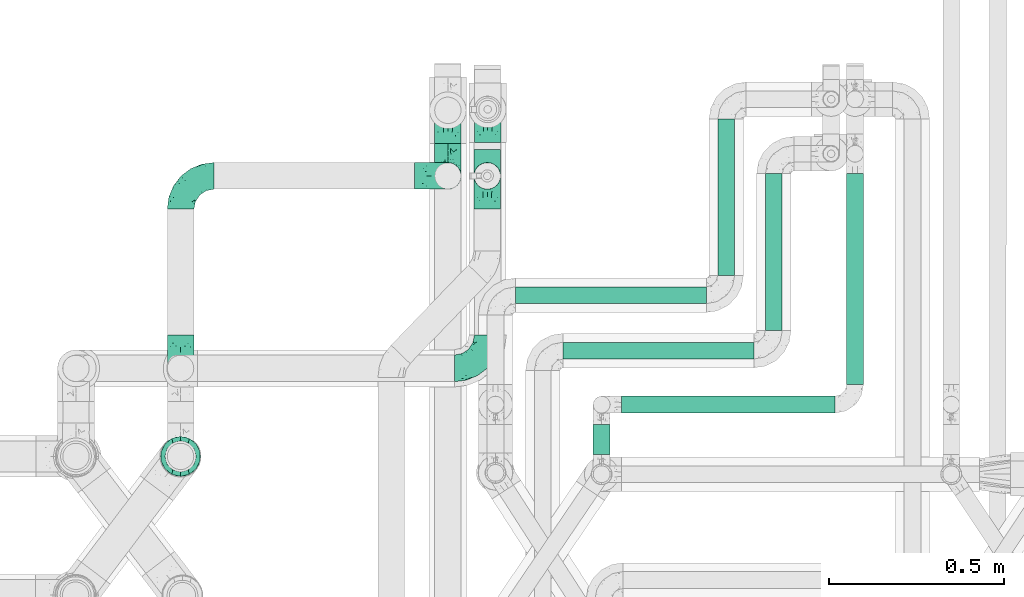
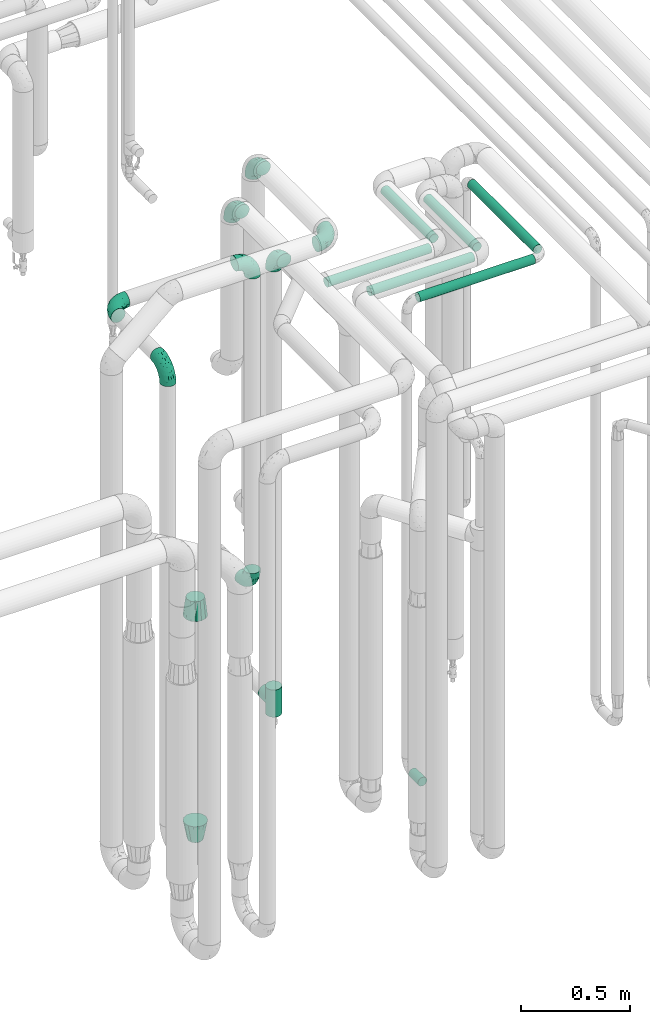
# One storey, part 671 of 824: 11 flow fittings, 7 flow segments.
"""IFC2X3 building model written with IfcOpenShell, lengths in millimetres."""

from ifc_helpers import new_model, entity, si_unit, converted_unit, derived_unit, direction, frame, origin, origin_2d_with_axis, place, context, subcontext, project, spatial, circle, extrude, faceted_brep, source, transform, mapped, material, type_object, type_shapes, element, save


model = new_model("IFC2X3")

# Units and contexts
model_context = context("Model", 3, precision=0.01, world=origin(), true_north=direction((6.12303176911189e-17, 1.0)))
body_context = subcontext(model_context, "Body", "Model", "MODEL_VIEW")
ifc_project = project(units=[si_unit("LENGTHUNIT", "METRE", prefix="MILLI"), si_unit("AREAUNIT", "SQUARE_METRE"), si_unit("VOLUMEUNIT", "CUBIC_METRE"), converted_unit("PLANEANGLEUNIT", "DEGREE", entity("IfcRatioMeasure", 0.0174532925199433), si_unit("PLANEANGLEUNIT", "RADIAN"), dimensions=[0, 0, 0, 0, 0, 0, 0]), si_unit("MASSUNIT", "GRAM", prefix="KILO"), derived_unit("MASSDENSITYUNIT", [(si_unit("MASSUNIT", "GRAM", prefix="KILO"), 1), (si_unit("LENGTHUNIT", "METRE"), -3)]), derived_unit("MOMENTOFINERTIAUNIT", [(si_unit("LENGTHUNIT", "METRE"), 4)]), si_unit("TIMEUNIT", "SECOND"), si_unit("FREQUENCYUNIT", "HERTZ"), si_unit("THERMODYNAMICTEMPERATUREUNIT", "DEGREE_CELSIUS"), derived_unit("THERMALTRANSMITTANCEUNIT", [(si_unit("MASSUNIT", "GRAM", prefix="KILO"), 1), (si_unit("THERMODYNAMICTEMPERATUREUNIT", "KELVIN"), -1), (si_unit("TIMEUNIT", "SECOND"), -3)]), derived_unit("VOLUMETRICFLOWRATEUNIT", [(si_unit("LENGTHUNIT", "METRE"), 3), (si_unit("TIMEUNIT", "SECOND"), -1)]), derived_unit("MASSFLOWRATEUNIT", [(si_unit("MASSUNIT", "GRAM", prefix="KILO"), 1), (si_unit("TIMEUNIT", "SECOND"), -1)]), derived_unit("ROTATIONALFREQUENCYUNIT", [(si_unit("TIMEUNIT", "SECOND"), -1)]), si_unit("ELECTRICCURRENTUNIT", "AMPERE"), si_unit("ELECTRICVOLTAGEUNIT", "VOLT"), si_unit("POWERUNIT", "WATT"), si_unit("FORCEUNIT", "NEWTON", prefix="KILO"), si_unit("ILLUMINANCEUNIT", "LUX"), si_unit("LUMINOUSFLUXUNIT", "LUMEN"), si_unit("LUMINOUSINTENSITYUNIT", "CANDELA"), derived_unit("USERDEFINED", [(si_unit("MASSUNIT", "GRAM", prefix="KILO"), -1), (si_unit("LENGTHUNIT", "METRE"), -2), (si_unit("TIMEUNIT", "SECOND"), 3), (si_unit("LUMINOUSFLUXUNIT", "LUMEN"), 1)]), derived_unit("LINEARVELOCITYUNIT", [(si_unit("LENGTHUNIT", "METRE"), 1), (si_unit("TIMEUNIT", "SECOND"), -1)]), si_unit("PRESSUREUNIT", "PASCAL"), derived_unit("USERDEFINED", [(si_unit("LENGTHUNIT", "METRE"), -2), (si_unit("MASSUNIT", "GRAM", prefix="KILO"), 1), (si_unit("TIMEUNIT", "SECOND"), -2)]), derived_unit("LINEARFORCEUNIT", [(si_unit("MASSUNIT", "GRAM", prefix="KILO"), 1), (si_unit("LENGTHUNIT", "METRE"), 1), (si_unit("TIMEUNIT", "SECOND"), -2), (si_unit("LENGTHUNIT", "METRE"), -1)]), derived_unit("PLANARFORCEUNIT", [(si_unit("MASSUNIT", "GRAM", prefix="KILO"), 1), (si_unit("LENGTHUNIT", "METRE"), 1), (si_unit("TIMEUNIT", "SECOND"), -2), (si_unit("LENGTHUNIT", "METRE"), -2)])], contexts=[model_context])

# Site, building, storey
site_placement = place(None, origin())
site = spatial("IfcSite", under=ifc_project, at=site_placement, CompositionType="ELEMENT")
building_placement = place(site_placement, origin())
building = spatial("IfcBuilding", under=site, at=building_placement, CompositionType="ELEMENT")
storey_placement = place(building_placement, frame((0.0, 0.0, 28200.0)))
storey = spatial("IfcBuildingStorey", under=building, at=storey_placement, CompositionType="ELEMENT", Elevation=28200.0)

# Flow segments
pipe_segment_type = type_object("IfcPipeSegmentType", PredefinedType="NOTDEFINED")
flow_segment_1_placement = place(storey_placement, frame((47694.42, 14491.53, 2974.4)))
element("IfcFlowSegment", 1, at=flow_segment_1_placement, inside=storey, type_object=pipe_segment_type, context=body_context, shape_type="SweptSolid", body=[
    extrude(circle(Radius=24.0, at=origin_2d_with_axis()), frame((25.6, 0.0, 25.6), z_axis=(0.0, 1.0, 0.0), x_axis=(1.0, 0.0, 0.0)), (0.0, 0.0, 1.0), 602.710728474916),
])
flow_segment_2_placement = place(storey_placement, frame((47462.4, 14645.75, 2974.4)))
element("IfcFlowSegment", 2, at=flow_segment_2_placement, inside=storey, type_object=pipe_segment_type, context=body_context, shape_type="SweptSolid", body=[
    extrude(circle(Radius=24.0, at=origin_2d_with_axis()), frame((25.6, 0.0, 25.6), z_axis=(0.0, 1.0, 0.0), x_axis=(-1.0, 0.0, 0.0)), (0.0, 0.0, 1.0), 448.489185095073),
])
flow_segment_3_placement = place(storey_placement, frame((47326.4, 14804.03, 2974.4)))
element("IfcFlowSegment", 3, at=flow_segment_3_placement, inside=storey, type_object=pipe_segment_type, context=body_context, shape_type="SweptSolid", body=[
    extrude(circle(Radius=24.0, at=origin_2d_with_axis()), frame((25.6, 0.0, 25.6), z_axis=(0.0, 1.0, 0.0), x_axis=(-1.0, 0.0, 0.0)), (0.0, 0.0, 1.0), 446.000000000016),
])
flow_segment_4_placement = place(storey_placement, frame((46970.44, 14292.68, 374.4)))
element("IfcFlowSegment", 4, at=flow_segment_4_placement, inside=storey, type_object=pipe_segment_type, context=body_context, shape_type="SweptSolid", body=[
    extrude(circle(Radius=24.0, at=origin_2d_with_axis()), frame((25.6, 0.0, 25.6), z_axis=(0.0, 1.0, 0.0), x_axis=(-1.0, 0.0, 0.0)), (0.0, 0.0, 1.0), 84.8501728348417),
])
flow_segment_5_placement = place(storey_placement, frame((47053.03, 14408.93, 2974.4)))
element("IfcFlowSegment", 5, at=flow_segment_5_placement, inside=storey, type_object=pipe_segment_type, context=body_context, shape_type="SweptSolid", body=[
    extrude(circle(Radius=24.0, at=origin_2d_with_axis()), frame((0.0, 25.6, 25.6), z_axis=(1.0, 0.0, 0.0), x_axis=(0.0, 1.0, 0.0)), (0.0, 0.0, 1.0), 609.986534506505),
])
flow_segment_6_placement = place(storey_placement, frame((46885.0, 14563.15, 2974.4)))
element("IfcFlowSegment", 6, at=flow_segment_6_placement, inside=storey, type_object=pipe_segment_type, context=body_context, shape_type="SweptSolid", body=[
    extrude(circle(Radius=24.0, at=origin_2d_with_axis()), frame((0.0, 25.6, 25.6), z_axis=(1.0, 0.0, 0.0), x_axis=(0.0, 1.0, 0.0)), (0.0, 0.0, 1.0), 546.000000000006),
])
flow_segment_7_placement = place(storey_placement, frame((46749.79, 14721.43, 2974.4)))
element("IfcFlowSegment", 7, at=flow_segment_7_placement, inside=storey, type_object=pipe_segment_type, context=body_context, shape_type="SweptSolid", body=[
    extrude(circle(Radius=24.0, at=origin_2d_with_axis()), frame((0.0, 25.6, 25.6), z_axis=(1.0, 0.0, 0.0), x_axis=(0.0, 1.0, 0.0)), (0.0, 0.0, 1.0), 545.208916433662),
])

# Flow fittings
ifc_material = material()
pipe_fitting_type_1 = type_object("IfcPipeFittingType", PredefinedType="NOTDEFINED", material=ifc_material)
shared_shape_1 = source(origin(), body_context, "Body", "Brep", [
    faceted_brep([(-95.0, 19.02, -32.95), (-95.0, 9.85, -36.75), (-95.0, 0.0, -38.05), (-95.0, -9.85, -36.75), (-95.0, -19.03, -32.95), (-95.0, -26.91, -26.91), (-95.0, -32.95, -19.03), (-95.0, -36.75, -9.85), (-95.0, -38.05, 0.0), (-95.0, -36.75, 9.85), (-95.0, -32.95, 19.02), (-95.0, -26.91, 26.91), (-95.0, -19.03, 32.95), (-95.0, -9.85, 36.75), (-95.0, 0.0, 38.05), (-95.0, 9.85, 36.75), (-95.0, 19.02, 32.95), (-95.0, 26.91, 26.91), (-95.0, 32.95, 19.02), (-95.0, 36.75, 9.85), (-95.0, 38.05, 0.0), (-95.0, 36.75, -9.85), (-95.0, 32.95, -19.03), (-95.0, 26.91, -26.91), (0.0, 95.0, -38.05), (-9.85, 95.0, -36.75), (-19.02, 95.0, -32.95), (-26.91, 95.0, -26.91), (-32.95, 95.0, -19.03), (-36.75, 95.0, -9.85), (-38.05, 95.0, 0.0), (-36.75, 95.0, 9.85), (-32.95, 95.0, 19.02), (-26.91, 95.0, 26.91), (-19.02, 95.0, 32.95), (-9.85, 95.0, 36.75), (0.0, 95.0, 38.05), (9.85, 95.0, 36.75), (19.03, 95.0, 32.95), (26.91, 95.0, 26.91), (32.95, 95.0, 19.02), (36.75, 95.0, 9.85), (38.05, 95.0, 0.0), (36.75, 95.0, -9.85), (32.95, 95.0, -19.03), (26.91, 95.0, -26.91), (19.03, 95.0, -32.95), (9.85, 95.0, -36.75), (-7.99, -4.96, 6.3), (-0.92, 0.92, 0.0), (4.62, 8.1, 8.01), (-76.19, -35.57, 0.0), (-64.32, -32.32, 12.43), (20.51, 62.45, 28.68), (-60.56, -33.52, 0.0), (-70.4, -13.47, 34.42), (-39.61, -5.88, 32.32), (-49.6, 2.07, 37.1), (-70.34, -28.81, 21.71), (14.64, 40.81, 26.5), (5.88, 39.61, 32.32), (3.59, 20.77, 25.31), (-40.45, 68.06, 16.75), (-62.45, -20.51, 28.68), (-44.52, -26.87, 0.0), (-28.47, -20.22, 0.0), (-26.43, -17.83, 8.75), (-76.1, 39.63, 10.76), (-72.74, 37.58, 18.19), (-60.35, 46.18, 14.61), (-13.4, 13.4, 32.12), (-20.77, -3.59, 25.31), (-14.66, 81.47, 35.56), (-6.22, 71.26, 37.92), (-57.5, 42.48, 22.79), (-15.0, 34.74, 37.7), (-27.1, 12.08, 36.05), (-9.2, 28.81, 35.63), (-79.98, 23.7, 30.95), (-73.68, -4.3, 37.48), (-30.74, 21.67, 37.97), (-62.36, 47.59, 6.79), (-72.71, 32.83, 24.69), (-67.42, 7.02, 37.95), (-32.13, 75.27, 24.51), (-43.46, 51.47, 26.26), (-24.98, 73.15, 31.29), (20.59, 41.28, 19.85), (7.79, 16.09, 15.86), (-73.21, 42.39, 0.0), (-54.73, 54.73, 0.0), (-73.44, 15.79, 35.79), (-5.94, 4.32, 20.43), (28.81, 70.34, 21.71), (32.32, 64.32, 12.43), (-53.59, 26.2, 35.09), (-52.02, 19.31, 37.21), (21.38, 33.53, 10.34), (26.87, 44.52, 0.0), (-48.28, 12.14, 38.05), (4.3, 73.68, 37.48), (-44.08, -25.52, 12.79), (-41.28, -20.59, 19.85), (35.57, 76.19, 0.0), (-47.26, 54.3, 20.18), (-47.4, 61.99, 8.58), (-42.39, 73.21, 0.0), (-39.67, 78.86, 7.21), (-45.69, 36.84, 33.11), (-32.83, 50.13, 33.35), (13.47, 70.4, 34.42), (-18.25, 63.73, 36.07), (-40.63, -13.75, 27.22), (-16.63, 46.37, 37.95), (-53.47, 38.79, 28.59), (-26.07, 48.54, 36.15), (-34.51, 34.51, 36.86), (-2.07, 49.6, 37.1), (-22.79, -10.49, 19.23), (-61.73, 28.67, 31.87), (9.65, 14.7, 0.0), (20.22, 28.47, 0.0), (33.52, 60.56, 0.0), (-11.42, -5.44, 13.25), (-14.7, -9.65, 0.0), (-81.47, 14.66, -35.56), (-62.45, -20.51, -28.68), (-71.26, 6.22, -37.92), (-75.27, 32.13, -24.51), (-73.15, 24.98, -31.29), (13.47, 70.4, -34.42), (5.88, 39.61, -32.32), (-2.07, 49.6, -37.1), (-78.86, 39.67, -7.21), (-70.4, -13.47, -34.42), (-39.61, -5.88, -32.32), (-61.99, 47.4, -8.58), (32.32, 64.32, -12.43), (28.81, 70.34, -21.71), (-63.73, 18.25, -36.07), (-50.13, 32.83, -33.35), (4.3, 73.68, -37.48), (-7.02, 67.42, -37.95), (-39.63, 76.1, -10.76), (-46.18, 60.35, -14.61), (-47.59, 62.36, -6.79), (-64.32, -32.32, -12.43), (-26.2, 53.59, -35.09), (-15.79, 73.44, -35.79), (-19.31, 52.02, -37.21), (-37.58, 72.74, -18.19), (-70.34, -28.81, -21.71), (-42.48, 57.5, -22.79), (-38.79, 53.47, -28.59), (-51.47, 43.46, -26.26), (-32.83, 72.71, -24.69), (-46.37, 16.63, -37.95), (-73.68, -4.3, -37.48), (-41.28, -20.59, -19.85), (-44.08, -25.52, -12.79), (13.75, 40.63, -27.22), (20.51, 62.45, -28.68), (-68.06, 40.45, -16.75), (-54.3, 47.26, -20.18), (-12.14, 48.28, -38.05), (-21.67, 30.74, -37.97), (-36.84, 45.69, -33.11), (-11.42, -5.44, -13.25), (7.79, 16.09, -15.86), (4.62, 8.1, -8.01), (-23.7, 79.98, -30.95), (-26.43, -17.83, -8.75), (-7.99, -4.96, -6.3), (-40.81, -14.64, -26.5), (-20.77, -3.59, -25.31), (-34.74, 15.0, -37.7), (-12.08, 27.1, -36.05), (-28.81, 9.2, -35.63), (-22.79, -10.49, -19.23), (21.38, 33.53, -10.34), (20.59, 41.28, -19.85), (-48.54, 26.07, -36.15), (-49.6, 2.07, -37.1), (-13.4, 13.4, -32.12), (3.59, 20.77, -25.31), (-28.67, 61.73, -31.87), (-34.51, 34.51, -36.86), (-5.94, 4.32, -20.43)], [[[0, 1, 2, 3, 4, 5, 6, 7, 8, 9, 10, 11, 12, 13, 14, 15, 16, 17, 18, 19, 20, 21, 22, 23]], [[24, 25, 26, 27, 28, 29, 30, 31, 32, 33, 34, 35, 36, 37, 38, 39, 40, 41, 42, 43, 44, 45, 46, 47]], [[48, 49, 50]], [[51, 52, 9]], [[53, 39, 38]], [[9, 52, 10]], [[54, 52, 51]], [[55, 56, 57]], [[11, 10, 58]], [[59, 60, 61]], [[32, 31, 62]], [[63, 12, 11]], [[63, 55, 12]], [[64, 65, 66]], [[67, 68, 69]], [[70, 56, 71]], [[35, 72, 73]], [[69, 68, 74]], [[75, 76, 77]], [[16, 78, 17]], [[13, 79, 14]], [[76, 75, 80]], [[67, 69, 81]], [[18, 17, 82]], [[14, 79, 83]], [[20, 19, 67]], [[84, 85, 86]], [[87, 61, 88]], [[89, 81, 90]], [[18, 82, 68]], [[15, 91, 16]], [[14, 83, 15]], [[71, 92, 61]], [[17, 78, 82]], [[93, 87, 94]], [[95, 91, 96]], [[97, 98, 94]], [[86, 72, 34]], [[96, 99, 80]], [[37, 36, 100]], [[40, 39, 93]], [[40, 94, 41]], [[64, 66, 101]], [[93, 94, 40]], [[58, 102, 63]], [[94, 103, 41]], [[94, 87, 97]], [[104, 69, 74]], [[34, 33, 86]], [[105, 69, 104]], [[52, 58, 10]], [[106, 107, 30]], [[108, 109, 85]], [[105, 106, 90]], [[53, 110, 60]], [[86, 111, 72]], [[86, 109, 111]], [[33, 84, 86]], [[12, 55, 13]], [[112, 56, 63]], [[110, 38, 37]], [[34, 72, 35]], [[36, 35, 73]], [[111, 113, 73]], [[105, 107, 106]], [[110, 53, 38]], [[74, 114, 85]], [[91, 15, 83]], [[105, 90, 81]], [[107, 62, 31]], [[33, 32, 84]], [[115, 109, 116]], [[111, 115, 113]], [[100, 73, 117]], [[56, 55, 63]], [[79, 55, 57]], [[102, 118, 112]], [[56, 70, 76]], [[100, 110, 37]], [[117, 77, 60]], [[117, 60, 110]], [[60, 70, 61]], [[58, 52, 101]], [[63, 11, 58]], [[39, 53, 93]], [[87, 93, 53]], [[96, 91, 83]], [[78, 91, 119]], [[32, 62, 84]], [[84, 62, 104]], [[86, 85, 109]], [[85, 114, 108]], [[80, 113, 116]], [[117, 73, 113]], [[80, 116, 96]], [[80, 57, 76]], [[71, 112, 118]], [[61, 87, 59]], [[62, 107, 105]], [[97, 120, 121]], [[70, 71, 61]], [[71, 118, 92]], [[73, 100, 36]], [[110, 100, 117]], [[55, 79, 13]], [[83, 79, 57]], [[96, 83, 99]], [[116, 108, 95]], [[50, 97, 88]], [[97, 87, 88]], [[50, 49, 120]], [[122, 94, 98]], [[89, 20, 67]], [[105, 81, 69]], [[89, 67, 81]], [[68, 19, 18]], [[68, 67, 19]], [[74, 68, 82]], [[114, 82, 119]], [[74, 85, 104]], [[82, 114, 74]], [[114, 119, 108]], [[95, 108, 119]], [[116, 109, 108]], [[123, 48, 50]], [[97, 50, 120]], [[123, 50, 88]], [[91, 95, 119]], [[116, 95, 96]], [[84, 104, 85]], [[104, 62, 105]], [[83, 57, 99]], [[57, 80, 99]], [[66, 48, 123]], [[66, 124, 48]], [[118, 66, 123]], [[124, 66, 65]], [[66, 118, 101]], [[54, 64, 52]], [[124, 49, 48]], [[30, 107, 31]], [[91, 78, 16]], [[82, 78, 119]], [[56, 76, 57]], [[77, 76, 70]], [[60, 77, 70]], [[77, 117, 75]], [[117, 113, 75]], [[113, 80, 75]], [[9, 8, 51]], [[103, 94, 122]], [[103, 42, 41]], [[73, 72, 111]], [[113, 115, 116]], [[111, 109, 115]], [[102, 112, 63]], [[71, 56, 112]], [[118, 102, 101]], [[92, 123, 88]], [[123, 92, 118]], [[61, 92, 88]], [[87, 53, 59]], [[60, 59, 53]], [[97, 121, 98]], [[58, 101, 102]], [[64, 101, 52]], [[125, 1, 0]], [[126, 5, 4]], [[2, 1, 127]], [[1, 125, 127]], [[128, 129, 23]], [[130, 131, 132]], [[89, 133, 20]], [[126, 134, 135]], [[136, 89, 90]], [[137, 138, 44]], [[139, 129, 140]], [[24, 141, 142]], [[143, 144, 145]], [[125, 129, 139]], [[6, 146, 7]], [[147, 148, 149]], [[146, 51, 7]], [[143, 150, 144]], [[146, 6, 151]], [[152, 153, 154]], [[126, 4, 134]], [[0, 23, 129]], [[28, 155, 150]], [[43, 42, 103]], [[54, 146, 64]], [[139, 156, 127]], [[157, 3, 2]], [[151, 158, 159]], [[160, 131, 161]], [[22, 21, 162]], [[136, 144, 163]], [[149, 164, 165]], [[24, 142, 25]], [[166, 140, 154]], [[154, 129, 128]], [[143, 30, 29]], [[167, 168, 169]], [[155, 28, 27]], [[26, 170, 27]], [[171, 167, 172]], [[26, 25, 148]], [[27, 170, 155]], [[173, 135, 174]], [[144, 150, 152]], [[175, 176, 177]], [[24, 47, 141]], [[45, 161, 46]], [[148, 25, 142]], [[176, 175, 165]], [[64, 159, 171]], [[138, 45, 44]], [[130, 46, 161]], [[137, 44, 43]], [[178, 159, 158]], [[137, 103, 122]], [[163, 144, 152]], [[136, 133, 89]], [[103, 137, 43]], [[6, 5, 151]], [[178, 158, 173]], [[134, 4, 3]], [[178, 173, 174]], [[137, 98, 179]], [[145, 90, 106]], [[138, 180, 161]], [[46, 130, 47]], [[136, 90, 145]], [[133, 162, 21]], [[23, 22, 128]], [[139, 140, 181]], [[139, 181, 156]], [[157, 127, 182]], [[157, 134, 3]], [[182, 177, 135]], [[182, 135, 134]], [[135, 183, 174]], [[131, 130, 161]], [[141, 130, 132]], [[160, 180, 184]], [[131, 183, 176]], [[5, 126, 151]], [[158, 151, 126]], [[180, 138, 137]], [[161, 45, 138]], [[149, 148, 142]], [[170, 148, 185]], [[22, 162, 128]], [[128, 162, 163]], [[129, 154, 140]], [[154, 153, 166]], [[165, 156, 186]], [[182, 127, 156]], [[165, 186, 149]], [[165, 132, 176]], [[131, 184, 183]], [[187, 167, 178]], [[184, 168, 187]], [[167, 169, 172]], [[184, 180, 168]], [[174, 183, 184]], [[127, 157, 2]], [[134, 157, 182]], [[130, 141, 47]], [[142, 141, 132]], [[149, 142, 164]], [[186, 166, 147]], [[180, 179, 168]], [[169, 179, 120]], [[137, 179, 180]], [[179, 121, 120]], [[106, 30, 143]], [[136, 145, 144]], [[106, 143, 145]], [[150, 29, 28]], [[150, 143, 29]], [[152, 150, 155]], [[153, 155, 185]], [[152, 154, 163]], [[155, 153, 152]], [[153, 185, 166]], [[147, 166, 185]], [[186, 140, 166]], [[169, 120, 49]], [[169, 49, 172]], [[179, 169, 168]], [[148, 147, 185]], [[186, 147, 149]], [[128, 163, 154]], [[163, 162, 136]], [[142, 132, 164]], [[132, 165, 164]], [[171, 124, 65]], [[124, 171, 172]], [[64, 146, 159]], [[171, 159, 178]], [[171, 65, 64]], [[172, 49, 124]], [[162, 133, 136]], [[20, 133, 21]], [[148, 170, 26]], [[155, 170, 185]], [[131, 176, 132]], [[177, 176, 183]], [[135, 177, 183]], [[177, 182, 175]], [[182, 156, 175]], [[156, 165, 175]], [[51, 146, 54]], [[51, 8, 7]], [[129, 125, 0]], [[127, 125, 139]], [[140, 186, 181]], [[156, 181, 186]], [[158, 126, 173]], [[135, 173, 126]], [[187, 178, 174]], [[171, 178, 167]], [[184, 187, 174]], [[167, 187, 168]], [[180, 160, 161]], [[184, 131, 160]], [[98, 137, 122]], [[98, 121, 179]], [[151, 159, 146]]]),
])
type_shapes(pipe_fitting_type_1, [shared_shape_1])
for number, where, z_axis, x_axis in (
    (8, (46669.38, 15088.04, 3000.0), (-1.0, 0.0, 0.0), (0.0, 1.0, 0.0)),
    (9, (46556.64, 15088.04, 1165.0), (1.0, 0.0, 0.0), (0.0, 0.0, -1.0)),
    (10, (46556.77, 15275.36, 3200.05), (-1.0, 0.0, 0.0), (0.0, 1.0, 0.0)),
):
    element("IfcFlowFitting", number, at=place(storey_placement, frame(where, z_axis=z_axis, x_axis=x_axis)), inside=storey, type_object=pipe_fitting_type_1, material=ifc_material, context=body_context, shape_type="MappedRepresentation", body=[
        mapped(shared_shape_1, transform((0.0, 0.0, 0.0), scale=1.0)),
    ])
flow_fitting_1_placement = place(storey_placement, frame((46670.56, 14538.08, 3400.0)))
element("IfcFlowFitting", 11, at=flow_fitting_1_placement, inside=storey, type_object=pipe_fitting_type_1, material=ifc_material, context=body_context, shape_type="MappedRepresentation", body=[
    mapped(shared_shape_1, transform((0.0, 0.0, 0.0), scale=1.0)),
])
for number, where, z_axis, x_axis in (
    (12, (46670.56, 15278.08, 3400.0), (-1.0, 0.0, 0.0), (0.0, 1.0, 0.0)),
    (13, (45793.07, 14538.08, 3000.0), (-1.0, 0.0, 0.0), (0.0, 0.0, 1.0)),
    (14, (45793.07, 15088.04, 3000.0), (0.0, 0.0, 1.0), (-1.0, 0.0, 0.0)),
    (15, (46556.64, 15088.04, 3000.0), (0.0, -1.0, 0.0), (0.0, 0.0, 1.0)),
):
    element("IfcFlowFitting", number, at=place(storey_placement, frame(where, z_axis=z_axis, x_axis=x_axis)), inside=storey, type_object=pipe_fitting_type_1, material=ifc_material, context=body_context, shape_type="MappedRepresentation", body=[
        mapped(shared_shape_1, transform((0.0, 0.0, 0.0), scale=1.0)),
    ])
pipe_fitting_type_2 = type_object("IfcPipeFittingType", PredefinedType="NOTDEFINED", material=ifc_material)
shared_shape_2 = source(origin(), body_context, "Body", "Brep", [
    faceted_brep([(-76.0, 9.85, -36.75), (-76.0, 0.0, -38.05), (-76.0, -9.85, -36.75), (-76.0, -19.03, -32.95), (-76.0, -22.97, -29.93), (-76.0, -26.91, -26.91), (-76.0, -29.93, -22.97), (-76.0, -32.95, -19.03), (-76.0, -34.85, -14.44), (-76.0, -36.75, -9.85), (-76.0, -38.05, 0.0), (-76.0, -36.75, 9.85), (-76.0, -34.85, 14.44), (-76.0, -32.95, 19.02), (-76.0, -29.93, 22.97), (-76.0, -26.91, 26.91), (-76.0, -22.97, 29.93), (-76.0, -19.03, 32.95), (-76.0, -9.85, 36.75), (-76.0, 0.0, 38.05), (-76.0, 9.85, 36.75), (-76.0, 19.02, 32.95), (-76.0, 26.91, 26.91), (-76.0, 32.95, 19.02), (-76.0, 36.75, 9.85), (-76.0, 38.05, 0.0), (-76.0, 36.75, -9.85), (-76.0, 32.95, -19.03), (-76.0, 26.91, -26.91), (-76.0, 19.02, -32.95), (76.0, 26.91, -26.91), (76.0, 32.95, -19.03), (76.0, 36.75, -9.85), (76.0, 38.05, 0.0), (76.0, 36.75, 9.85), (76.0, 32.95, 19.02), (76.0, 26.91, 26.91), (76.0, 19.02, 32.95), (76.0, 9.85, 36.75), (76.0, 0.0, 38.05), (76.0, -9.85, 36.75), (76.0, -19.03, 32.95), (76.0, -22.97, 29.93), (76.0, -26.91, 26.91), (76.0, -29.93, 22.97), (76.0, -32.95, 19.02), (76.0, -34.85, 14.44), (76.0, -36.75, 9.85), (76.0, -38.05, 0.0), (76.0, -36.75, -9.85), (76.0, -34.85, -14.44), (76.0, -32.95, -19.03), (76.0, -29.93, -22.97), (76.0, -26.91, -26.91), (76.0, -22.97, -29.93), (76.0, -19.03, -32.95), (76.0, -9.85, -36.75), (76.0, 0.0, -38.05), (76.0, 9.85, -36.75), (76.0, 19.02, -32.95), (36.99, -36.99, 8.94), (38.05, -38.05, 0.0), (-36.99, -36.99, 8.94), (-38.05, -38.05, 0.0), (35.51, -35.51, 12.97), (34.04, -34.04, 17.0), (18.81, -18.81, 33.08), (29.74, -29.74, 23.73), (24.56, -24.56, 29.06), (-35.51, -35.51, 12.97), (-34.04, -34.04, 17.0), (-18.81, -18.81, 33.08), (-29.74, -29.74, 23.73), (-24.56, -24.56, 29.06), (-12.7, -12.7, 35.87), (6.4, -6.4, 37.51), (12.7, -12.7, 35.87), (0.0, 0.0, 38.05), (-6.4, -6.4, 37.51), (6.4, -6.4, -37.51), (0.0, 0.0, -38.05), (12.7, -12.7, -35.87), (-24.56, -24.56, -29.06), (-6.4, -6.4, -37.51), (-35.51, -35.51, -12.97), (-36.99, -36.99, -8.94), (-29.74, -29.74, -23.73), (-12.7, -12.7, -35.87), (18.81, -18.81, -33.08), (24.56, -24.56, -29.06), (-34.04, -34.04, -17.0), (29.74, -29.74, -23.73), (36.99, -36.99, -8.94), (35.51, -35.51, -12.97), (34.04, -34.04, -17.0), (-18.81, -18.81, -33.08), (9.85, -76.0, -36.75), (19.03, -76.0, -32.95), (26.91, -76.0, -26.91), (32.95, -76.0, -19.03), (36.75, -76.0, -9.85), (38.05, -76.0, 0.0), (36.75, -76.0, 9.85), (32.95, -76.0, 19.02), (26.91, -76.0, 26.91), (19.03, -76.0, 32.95), (9.85, -76.0, 36.75), (0.0, -76.0, 38.05), (-9.85, -76.0, 36.75), (-19.02, -76.0, 32.95), (-26.91, -76.0, 26.91), (-32.95, -76.0, 19.02), (-36.75, -76.0, 9.85), (-38.05, -76.0, 0.0), (-36.75, -76.0, -9.85), (-32.95, -76.0, -19.03), (-26.91, -76.0, -26.91), (-19.02, -76.0, -32.95), (-9.85, -76.0, -36.75), (0.0, -76.0, -38.05)], [[[0, 1, 2, 3, 4, 5, 6, 7, 8, 9, 10, 11, 12, 13, 14, 15, 16, 17, 18, 19, 20, 21, 22, 23, 24, 25, 26, 27, 28, 29]], [[30, 31, 32, 33, 34, 35, 36, 37, 38, 39, 40, 41, 42, 43, 44, 45, 46, 47, 48, 49, 50, 51, 52, 53, 54, 55, 56, 57, 58, 59]], [[48, 47, 60]], [[60, 61, 48]], [[62, 10, 63]], [[47, 46, 64]], [[46, 45, 65]], [[41, 66, 42]], [[43, 67, 45, 44]], [[67, 43, 68]], [[45, 67, 65]], [[68, 43, 42]], [[11, 69, 12]], [[70, 12, 69]], [[10, 62, 11]], [[11, 62, 69]], [[71, 17, 16]], [[72, 73, 15]], [[72, 15, 14, 13]], [[15, 73, 16]], [[71, 74, 17]], [[72, 13, 70]], [[46, 65, 64]], [[42, 66, 68]], [[40, 39, 75]], [[47, 64, 60]], [[66, 41, 76]], [[75, 76, 40]], [[75, 39, 77]], [[78, 77, 19]], [[76, 41, 40]], [[23, 22, 36, 35]], [[24, 23, 35, 34]], [[21, 20, 38, 37]], [[22, 21, 37, 36]], [[38, 20, 19, 77, 39]], [[25, 24, 34, 33]], [[70, 13, 12]], [[78, 18, 74]], [[18, 78, 19]], [[18, 17, 74]], [[71, 16, 73]], [[28, 27, 31, 30]], [[26, 32, 31, 27]], [[25, 33, 32, 26]], [[29, 28, 30, 59]], [[57, 56, 79]], [[58, 57, 80, 1, 0]], [[79, 56, 81]], [[82, 5, 4]], [[59, 58, 0, 29]], [[56, 55, 81]], [[57, 79, 80]], [[80, 83, 1]], [[9, 84, 85]], [[86, 7, 6, 5]], [[83, 87, 2]], [[1, 83, 2]], [[87, 3, 2]], [[88, 54, 89]], [[54, 53, 89]], [[8, 90, 84]], [[88, 55, 54]], [[91, 89, 53]], [[52, 51, 91, 53]], [[55, 88, 81]], [[49, 92, 93]], [[92, 49, 48]], [[94, 50, 93]], [[61, 92, 48]], [[85, 63, 10]], [[51, 94, 91]], [[82, 4, 95]], [[49, 93, 50]], [[4, 3, 95]], [[5, 82, 86]], [[94, 51, 50]], [[95, 3, 87]], [[9, 8, 84]], [[90, 8, 7]], [[9, 85, 10]], [[90, 7, 86]], [[96, 97, 98, 99, 100, 101, 102, 103, 104, 105, 106, 107, 108, 109, 110, 111, 112, 113, 114, 115, 116, 117, 118, 119]], [[62, 63, 113]], [[112, 62, 113]], [[110, 109, 73]], [[72, 111, 110]], [[70, 112, 111]], [[74, 109, 108]], [[112, 70, 69, 62]], [[73, 72, 110]], [[70, 111, 72]], [[74, 71, 109]], [[107, 77, 78]], [[74, 108, 78]], [[73, 109, 71]], [[78, 108, 107]], [[75, 107, 106]], [[105, 76, 106]], [[103, 102, 65]], [[67, 104, 103]], [[68, 105, 104]], [[60, 102, 101]], [[68, 66, 105]], [[76, 75, 106]], [[66, 76, 105]], [[61, 60, 101]], [[65, 67, 103]], [[102, 60, 64, 65]], [[68, 104, 67]], [[107, 75, 77]], [[61, 101, 92]], [[100, 92, 101]], [[98, 97, 89]], [[94, 100, 99]], [[98, 91, 99]], [[81, 97, 96]], [[100, 94, 93, 92]], [[89, 91, 98]], [[94, 99, 91]], [[81, 88, 97]], [[119, 80, 79]], [[81, 96, 79]], [[89, 97, 88]], [[79, 96, 119]], [[83, 119, 118]], [[117, 87, 118]], [[115, 114, 90]], [[86, 116, 115]], [[82, 117, 116]], [[85, 114, 113]], [[82, 95, 117]], [[87, 83, 118]], [[95, 87, 117]], [[63, 85, 113]], [[90, 86, 115]], [[114, 85, 84, 90]], [[82, 116, 86]], [[119, 83, 80]]]),
])
type_shapes(pipe_fitting_type_2, [shared_shape_2])
flow_fitting_2_placement = place(storey_placement, frame((46669.38, 15088.04, 494.0), z_axis=(-1.0, 0.0, 0.0), x_axis=(0.0, 0.0, -1.0)))
element("IfcFlowFitting", 16, at=flow_fitting_2_placement, inside=storey, type_object=pipe_fitting_type_2, material=ifc_material, context=body_context, shape_type="MappedRepresentation", body=[
    mapped(shared_shape_2, transform((0.0, 0.0, 0.0), scale=1.0)),
])
pipe_fitting_type_3 = type_object("IfcPipeFittingType", PredefinedType="NOTDEFINED", material=ifc_material)
shared_shape_3 = source(origin(), body_context, "Body", "Brep", [
    faceted_brep([(102.0, -30.36, 30.36), (102.0, -38.49, 22.23), (102.0, -41.47, 11.11), (102.0, -44.45, 0.0), (102.0, -41.47, -11.11), (102.0, -38.49, -22.22), (102.0, -30.36, -30.36), (102.0, -22.23, -38.49), (102.0, -11.11, -41.47), (102.0, 0.0, -44.45), (102.0, 11.11, -41.47), (102.0, 22.22, -38.49), (102.0, 30.36, -30.36), (102.0, 38.49, -22.22), (102.0, 41.47, -11.11), (102.0, 44.45, 0.0), (102.0, 41.47, 11.11), (102.0, 38.49, 22.23), (102.0, 30.36, 30.36), (102.0, 22.22, 38.49), (102.0, 11.11, 41.47), (102.0, 0.0, 44.45), (102.0, -11.11, 41.47), (102.0, -22.23, 38.49), (0.0, 24.17, 50.2), (0.0, 35.63, 44.68), (0.0, 43.56, 34.74), (0.0, 51.49, 24.8), (0.0, 54.32, 12.4), (0.0, 57.15, 0.0), (0.0, 54.32, -12.4), (0.0, 51.49, -24.8), (0.0, 43.56, -34.74), (0.0, 35.63, -44.68), (0.0, 24.17, -50.2), (0.0, 12.72, -55.72), (0.0, 0.0, -55.72), (0.0, -12.72, -55.72), (0.0, -24.17, -50.2), (0.0, -35.63, -44.68), (0.0, -43.56, -34.74), (0.0, -51.49, -24.8), (0.0, -54.32, -12.4), (0.0, -57.15, 0.0), (0.0, -54.32, 12.4), (0.0, -51.49, 24.8), (0.0, -43.56, 34.74), (0.0, -35.63, 44.68), (0.0, -24.17, 50.2), (0.0, -12.72, 55.72), (0.0, 0.0, 55.72), (0.0, 12.72, 55.72)], [[[0, 1, 2, 3, 4, 5, 6, 7, 8, 9, 10, 11, 12, 13, 14, 15, 16, 17, 18, 19, 20, 21, 22, 23]], [[24, 25, 26, 27, 28, 29, 30, 31, 32, 33, 34, 35, 36, 37, 38, 39, 40, 41, 42, 43, 44, 45, 46, 47, 48, 49, 50, 51]], [[14, 31, 30]], [[42, 3, 43]], [[32, 31, 13]], [[13, 31, 14]], [[34, 10, 35]], [[3, 42, 4]], [[12, 11, 33]], [[9, 37, 36, 35]], [[7, 39, 38]], [[39, 7, 6]], [[38, 8, 7]], [[34, 33, 11]], [[10, 9, 35]], [[40, 5, 41]], [[12, 33, 32]], [[15, 30, 29]], [[38, 37, 8]], [[15, 14, 30]], [[41, 5, 4]], [[5, 40, 6]], [[13, 12, 32]], [[10, 34, 11]], [[37, 9, 8]], [[40, 39, 6]], [[42, 41, 4]], [[2, 45, 44]], [[28, 15, 29]], [[46, 45, 1]], [[1, 45, 2]], [[48, 22, 49]], [[15, 28, 16]], [[0, 23, 47]], [[21, 51, 50, 49]], [[19, 25, 24]], [[25, 19, 18]], [[24, 20, 19]], [[48, 47, 23]], [[22, 21, 49]], [[26, 17, 27]], [[0, 47, 46]], [[3, 44, 43]], [[24, 51, 20]], [[3, 2, 44]], [[27, 17, 16]], [[17, 26, 18]], [[1, 0, 46]], [[22, 48, 23]], [[51, 21, 20]], [[26, 25, 18]], [[28, 27, 16]]]),
])
type_shapes(pipe_fitting_type_3, [shared_shape_3])
flow_fitting_3_placement = place(storey_placement, frame((45793.07, 14286.62, 1758.0), z_axis=(1.0, 0.0, 0.0), x_axis=(0.0, 0.0, 1.0)))
element("IfcFlowFitting", 17, at=flow_fitting_3_placement, inside=storey, type_object=pipe_fitting_type_3, material=ifc_material, context=body_context, shape_type="MappedRepresentation", body=[
    mapped(shared_shape_3, transform((0.0, 0.0, 0.0), scale=1.0)),
])
pipe_fitting_type_4 = type_object("IfcPipeFittingType", PredefinedType="NOTDEFINED", material=ifc_material)
shared_shape_4 = source(origin(), body_context, "Body", "Brep", [
    faceted_brep([(102.0, -57.15, 0.0), (102.0, -54.32, -12.4), (102.0, -51.49, -24.8), (102.0, -43.56, -34.74), (102.0, -35.63, -44.68), (102.0, -24.17, -50.2), (102.0, -12.72, -55.72), (102.0, 0.0, -55.72), (102.0, 12.72, -55.72), (102.0, 24.17, -50.2), (102.0, 35.63, -44.68), (102.0, 43.56, -34.74), (102.0, 51.49, -24.8), (102.0, 54.32, -12.4), (102.0, 57.15, 0.0), (102.0, 54.32, 12.4), (102.0, 51.49, 24.8), (102.0, 43.56, 34.74), (102.0, 35.63, 44.68), (102.0, 24.17, 50.2), (102.0, 12.72, 55.72), (102.0, 0.0, 55.72), (102.0, -12.72, 55.72), (102.0, -24.17, 50.2), (102.0, -35.63, 44.68), (102.0, -43.56, 34.74), (102.0, -51.49, 24.8), (102.0, -54.32, 12.4), (0.0, 38.05, 0.0), (0.0, 35.5, -9.51), (0.0, 32.95, -19.02), (0.0, 25.99, -25.99), (0.0, 19.02, -32.95), (0.0, 9.51, -35.5), (0.0, 0.0, -38.05), (0.0, -9.51, -35.5), (0.0, -19.02, -32.95), (0.0, -25.99, -25.99), (0.0, -32.95, -19.02), (0.0, -35.5, -9.51), (0.0, -38.05, 0.0), (0.0, -35.5, 9.51), (0.0, -32.95, 19.03), (0.0, -25.99, 25.99), (0.0, -19.03, 32.95), (0.0, -9.51, 35.5), (0.0, 0.0, 38.05), (0.0, 9.51, 35.5), (0.0, 19.03, 32.95), (0.0, 25.99, 25.99), (0.0, 32.95, 19.03), (0.0, 35.5, 9.51)], [[[0, 1, 2, 3, 4, 5, 6, 7, 8, 9, 10, 11, 12, 13, 14, 15, 16, 17, 18, 19, 20, 21, 22, 23, 24, 25, 26, 27]], [[28, 29, 30, 31, 32, 33, 34, 35, 36, 37, 38, 39, 40, 41, 42, 43, 44, 45, 46, 47, 48, 49, 50, 51]], [[38, 2, 39]], [[11, 10, 31]], [[8, 34, 33]], [[3, 2, 38]], [[40, 39, 1]], [[28, 13, 29]], [[40, 1, 0]], [[32, 10, 9]], [[34, 8, 7, 6]], [[37, 36, 4]], [[39, 2, 1]], [[33, 32, 9]], [[38, 37, 3]], [[37, 4, 3]], [[5, 4, 36]], [[13, 28, 14]], [[10, 32, 31]], [[8, 33, 9]], [[35, 5, 36]], [[30, 11, 31]], [[29, 12, 30]], [[5, 35, 6]], [[35, 34, 6]], [[11, 30, 12]], [[13, 12, 29]], [[50, 16, 51]], [[25, 24, 43]], [[22, 46, 45]], [[17, 16, 50]], [[28, 51, 15]], [[40, 27, 41]], [[28, 15, 14]], [[44, 24, 23]], [[46, 22, 21, 20]], [[49, 48, 18]], [[51, 16, 15]], [[45, 44, 23]], [[50, 49, 17]], [[49, 18, 17]], [[19, 18, 48]], [[27, 40, 0]], [[24, 44, 43]], [[22, 45, 23]], [[47, 19, 48]], [[42, 25, 43]], [[41, 26, 42]], [[19, 47, 20]], [[47, 46, 20]], [[25, 42, 26]], [[27, 26, 41]]]),
])
type_shapes(pipe_fitting_type_4, [shared_shape_4])
flow_fitting_4_placement = place(storey_placement, frame((45793.07, 14286.62, 510.0), z_axis=(0.0, 1.0, 0.0), x_axis=(0.0, 0.0, 1.0)))
element("IfcFlowFitting", 18, at=flow_fitting_4_placement, inside=storey, type_object=pipe_fitting_type_4, material=ifc_material, context=body_context, shape_type="MappedRepresentation", body=[
    mapped(shared_shape_4, transform((0.0, 0.0, 0.0), scale=1.0)),
])

save(model, "model.ifc")
